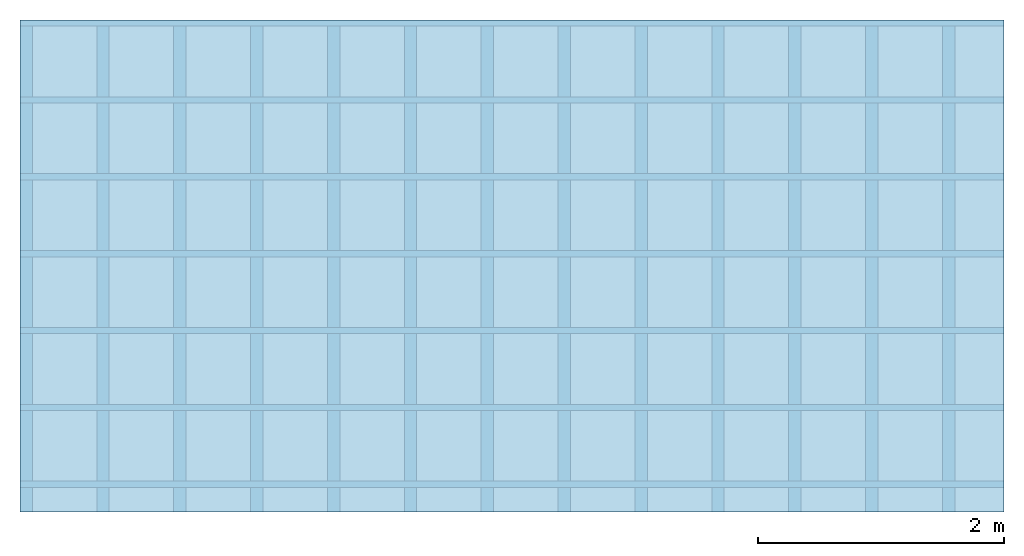
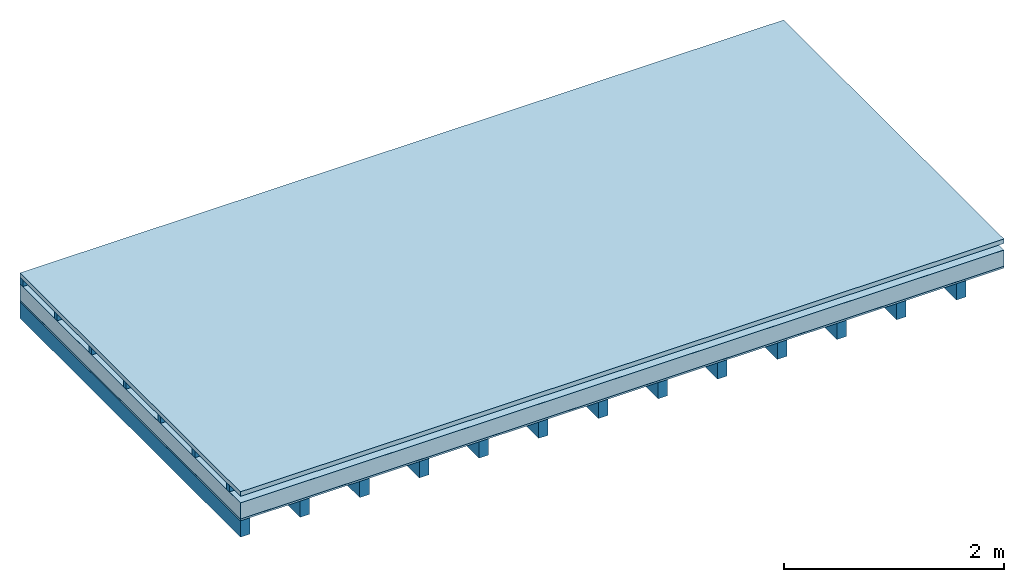
# One storey: 5 plates, 2 members, 1 element without a shape of its own.
"""IFC4 building model written with IfcOpenShell, lengths in metres."""

from ifc_helpers import new_model, si_unit, derived_unit, direction, frame, frame_2d, origin, origin_with_axes, place, context, project, spatial, rectangle, extrude, material, layer, layer_set, type_object, element, aggregate, save


model = new_model("IFC4")

# Units and contexts
plan_context = context("Plan", 3, precision=1e-05, world=origin(), true_north=direction((0.0, 1.0)))
model_context = context("Model", 3, precision=1e-05, world=origin(), true_north=direction((0.0, 1.0)))
ifc_project = project(units=[si_unit("LENGTHUNIT", "METRE"), derived_unit("SOUNDPRESSUREUNIT", [(si_unit("PRESSUREUNIT", "PASCAL", prefix="MICRO"), 0)]), si_unit("ENERGYUNIT", "JOULE", prefix="MEGA"), si_unit("MASSUNIT", "GRAM", prefix="KILO"), derived_unit("THERMALTRANSMITTANCEUNIT", [(si_unit("POWERUNIT", "WATT"), 1), (si_unit("AREAUNIT", "SQUARE_METRE"), -1), (si_unit("THERMODYNAMICTEMPERATUREUNIT", "KELVIN"), -1)]), derived_unit("AREADENSITYUNIT", [(si_unit("MASSUNIT", "GRAM", prefix="KILO"), 1), (si_unit("AREAUNIT", "SQUARE_METRE"), -1)]), derived_unit("USERDEFINED", [(si_unit("ENERGYUNIT", "JOULE", prefix="MEGA"), 1), (si_unit("AREAUNIT", "SQUARE_METRE"), -1)])], contexts=[plan_context, model_context])

# Site, building, storey
site = spatial("IfcSite", under=ifc_project)
building_placement = place(None, origin())
building = spatial("IfcBuilding", under=site, at=building_placement)
storey_placement = place(building_placement, origin())
storey = spatial("IfcBuildingStorey", under=building, at=storey_placement)

# Slab, members, plates
ifc_material_1 = material(Name="Roof tiles", Category="03.015")
ifc_layer_1 = layer(ifc_material_1, 0.05, Name="Roofing")
ifc_layer_2 = layer(None, 0.072, Name="Battens / profiles")
ifc_material_2 = material(Name="Roofing underlay", Category="09.008")
ifc_layer_3 = layer(ifc_material_2, 0.00018, Name="Under the roof")
ifc_material_3 = material(Category="10.009")
ifc_layer_4 = layer(ifc_material_3, 0.18, Name="Exterior insulation layer 1")
ifc_material_4 = material(Name="Vapor barrier polyethylene (PE)", Category="09.002")
ifc_layer_5 = layer(ifc_material_4, 0.00018, Name="above 1st layer")
ifc_material_5 = material(Name="Boards with edges", Category="07.009")
ifc_layer_6 = layer(ifc_material_5, 0.02, Name="Sub-floor")
ifc_material_6 = material(Name="of the art")
ifc_layer_7 = layer(ifc_material_6, 0.0, Name="Bond")
ifc_layer_8 = layer(None, 0.18, Name="Supporting structure")
ifc_layer_set = layer_set([ifc_layer_1, ifc_layer_2, ifc_layer_3, ifc_layer_4, ifc_layer_5, ifc_layer_6, ifc_layer_7, ifc_layer_8])
slab_type = type_object("IfcSlabType", Name="E0172", PredefinedType="NOTDEFINED", material=ifc_layer_set)
slab_placement = place(None, frame((0.0, 0.0, 0.0), z_axis=(0.0, 0.0, -1.0), x_axis=(1.0, 0.0, 0.0)))
slab = element("IfcSlab", 1, at=slab_placement, inside=storey, type_object=slab_type, material=ifc_layer_set, Name="Slab #1")
ifc_material_7 = material()
member_1_placement = place(slab_placement, origin())
member_1 = element("IfcMember", 2, at=member_1_placement, material=ifc_material_7, Name="Battens / profiles", context=plan_context, shape_type="SweptSolid", body=[
    extrude(rectangle(XDim=0.05, YDim=0.072, at=frame_2d((0.025, 0.036), x_axis=(1.0, 0.0))), frame((0.0, 0.0, 0.05), z_axis=(1.0, 0.0, 0.0), x_axis=(0.0, 1.0, 0.0)), (0.0, 0.0, 1.0), 8.0),
    extrude(rectangle(XDim=0.05, YDim=0.072, at=frame_2d((0.025, 0.036), x_axis=(1.0, 0.0))), frame((0.0, 0.625, 0.05), z_axis=(1.0, 0.0, 0.0), x_axis=(0.0, 1.0, 0.0)), (0.0, 0.0, 1.0), 8.0),
    extrude(rectangle(XDim=0.05, YDim=0.072, at=frame_2d((0.025, 0.036), x_axis=(1.0, 0.0))), frame((0.0, 1.25, 0.05), z_axis=(1.0, 0.0, 0.0), x_axis=(0.0, 1.0, 0.0)), (0.0, 0.0, 1.0), 8.0),
    extrude(rectangle(XDim=0.05, YDim=0.072, at=frame_2d((0.025, 0.036), x_axis=(1.0, 0.0))), frame((0.0, 1.875, 0.05), z_axis=(1.0, 0.0, 0.0), x_axis=(0.0, 1.0, 0.0)), (0.0, 0.0, 1.0), 8.0),
    extrude(rectangle(XDim=0.05, YDim=0.072, at=frame_2d((0.025, 0.036), x_axis=(1.0, 0.0))), frame((0.0, 2.5, 0.05), z_axis=(1.0, 0.0, 0.0), x_axis=(0.0, 1.0, 0.0)), (0.0, 0.0, 1.0), 8.0),
    extrude(rectangle(XDim=0.05, YDim=0.072, at=frame_2d((0.025, 0.036), x_axis=(1.0, 0.0))), frame((0.0, 3.125, 0.05), z_axis=(1.0, 0.0, 0.0), x_axis=(0.0, 1.0, 0.0)), (0.0, 0.0, 1.0), 8.0),
    extrude(rectangle(XDim=0.05, YDim=0.072, at=frame_2d((0.025, 0.036), x_axis=(1.0, 0.0))), frame((0.0, 3.75, 0.05), z_axis=(1.0, 0.0, 0.0), x_axis=(0.0, 1.0, 0.0)), (0.0, 0.0, 1.0), 8.0),
])
ifc_material_8 = material()
member_2_placement = place(slab_placement, origin())
member_2 = element("IfcMember", 3, at=member_2_placement, material=ifc_material_8, Name="Supporting structure", context=plan_context, shape_type="SweptSolid", body=[
    extrude(rectangle(XDim=0.1, YDim=0.18, at=frame_2d((0.05, 0.09), x_axis=(1.0, 0.0))), frame((0.0, 4.0, 0.32236), z_axis=(0.0, -1.0, 0.0), x_axis=(1.0, 0.0, 0.0)), (0.0, 0.0, 1.0), 4.0),
    extrude(rectangle(XDim=0.1, YDim=0.18, at=frame_2d((0.05, 0.09), x_axis=(1.0, 0.0))), frame((0.625, 4.0, 0.32236), z_axis=(0.0, -1.0, 0.0), x_axis=(1.0, 0.0, 0.0)), (0.0, 0.0, 1.0), 4.0),
    extrude(rectangle(XDim=0.1, YDim=0.18, at=frame_2d((0.05, 0.09), x_axis=(1.0, 0.0))), frame((1.25, 4.0, 0.32236), z_axis=(0.0, -1.0, 0.0), x_axis=(1.0, 0.0, 0.0)), (0.0, 0.0, 1.0), 4.0),
    extrude(rectangle(XDim=0.1, YDim=0.18, at=frame_2d((0.05, 0.09), x_axis=(1.0, 0.0))), frame((1.875, 4.0, 0.32236), z_axis=(0.0, -1.0, 0.0), x_axis=(1.0, 0.0, 0.0)), (0.0, 0.0, 1.0), 4.0),
    extrude(rectangle(XDim=0.1, YDim=0.18, at=frame_2d((0.05, 0.09), x_axis=(1.0, 0.0))), frame((2.5, 4.0, 0.32236), z_axis=(0.0, -1.0, 0.0), x_axis=(1.0, 0.0, 0.0)), (0.0, 0.0, 1.0), 4.0),
    extrude(rectangle(XDim=0.1, YDim=0.18, at=frame_2d((0.05, 0.09), x_axis=(1.0, 0.0))), frame((3.125, 4.0, 0.32236), z_axis=(0.0, -1.0, 0.0), x_axis=(1.0, 0.0, 0.0)), (0.0, 0.0, 1.0), 4.0),
    extrude(rectangle(XDim=0.1, YDim=0.18, at=frame_2d((0.05, 0.09), x_axis=(1.0, 0.0))), frame((3.75, 4.0, 0.32236), z_axis=(0.0, -1.0, 0.0), x_axis=(1.0, 0.0, 0.0)), (0.0, 0.0, 1.0), 4.0),
    extrude(rectangle(XDim=0.1, YDim=0.18, at=frame_2d((0.05, 0.09), x_axis=(1.0, 0.0))), frame((4.375, 4.0, 0.32236), z_axis=(0.0, -1.0, 0.0), x_axis=(1.0, 0.0, 0.0)), (0.0, 0.0, 1.0), 4.0),
    extrude(rectangle(XDim=0.1, YDim=0.18, at=frame_2d((0.05, 0.09), x_axis=(1.0, 0.0))), frame((5.0, 4.0, 0.32236), z_axis=(0.0, -1.0, 0.0), x_axis=(1.0, 0.0, 0.0)), (0.0, 0.0, 1.0), 4.0),
    extrude(rectangle(XDim=0.1, YDim=0.18, at=frame_2d((0.05, 0.09), x_axis=(1.0, 0.0))), frame((5.625, 4.0, 0.32236), z_axis=(0.0, -1.0, 0.0), x_axis=(1.0, 0.0, 0.0)), (0.0, 0.0, 1.0), 4.0),
    extrude(rectangle(XDim=0.1, YDim=0.18, at=frame_2d((0.05, 0.09), x_axis=(1.0, 0.0))), frame((6.25, 4.0, 0.32236), z_axis=(0.0, -1.0, 0.0), x_axis=(1.0, 0.0, 0.0)), (0.0, 0.0, 1.0), 4.0),
    extrude(rectangle(XDim=0.1, YDim=0.18, at=frame_2d((0.05, 0.09), x_axis=(1.0, 0.0))), frame((6.875, 4.0, 0.32236), z_axis=(0.0, -1.0, 0.0), x_axis=(1.0, 0.0, 0.0)), (0.0, 0.0, 1.0), 4.0),
    extrude(rectangle(XDim=0.1, YDim=0.18, at=frame_2d((0.05, 0.09), x_axis=(1.0, 0.0))), frame((7.5, 4.0, 0.32236), z_axis=(0.0, -1.0, 0.0), x_axis=(1.0, 0.0, 0.0)), (0.0, 0.0, 1.0), 4.0),
])
plate_1_placement = place(slab_placement, origin())
plate_1 = element("IfcPlate", 4, at=plate_1_placement, material=ifc_material_1, Name="Roofing", context=plan_context, shape_type="SweptSolid", body=[
    extrude(rectangle(XDim=8.0, YDim=4.0, at=frame_2d((4.0, 2.0), x_axis=(1.0, 0.0))), origin_with_axes(), (0.0, 0.0, 1.0), 0.05),
])
plate_2_placement = place(slab_placement, origin())
plate_2 = element("IfcPlate", 5, at=plate_2_placement, material=ifc_material_2, Name="Under the roof", context=plan_context, shape_type="SweptSolid", body=[
    extrude(rectangle(XDim=8.0, YDim=4.0, at=frame_2d((4.0, 2.0), x_axis=(1.0, 0.0))), frame((0.0, 0.0, 0.122), z_axis=(0.0, 0.0, 1.0), x_axis=(1.0, 0.0, 0.0)), (0.0, 0.0, 1.0), 0.00018),
])
plate_3_placement = place(slab_placement, origin())
plate_3 = element("IfcPlate", 6, at=plate_3_placement, material=ifc_material_3, Name="Exterior insulation layer 1", context=plan_context, shape_type="SweptSolid", body=[
    extrude(rectangle(XDim=8.0, YDim=4.0, at=frame_2d((4.0, 2.0), x_axis=(1.0, 0.0))), frame((0.0, 0.0, 0.12218), z_axis=(0.0, 0.0, 1.0), x_axis=(1.0, 0.0, 0.0)), (0.0, 0.0, 1.0), 0.18),
])
plate_4_placement = place(slab_placement, origin())
plate_4 = element("IfcPlate", 7, at=plate_4_placement, material=ifc_material_4, Name="above 1st layer", context=plan_context, shape_type="SweptSolid", body=[
    extrude(rectangle(XDim=8.0, YDim=4.0, at=frame_2d((4.0, 2.0), x_axis=(1.0, 0.0))), frame((0.0, 0.0, 0.30218), z_axis=(0.0, 0.0, 1.0), x_axis=(1.0, 0.0, 0.0)), (0.0, 0.0, 1.0), 0.00018),
])
plate_5_placement = place(slab_placement, origin())
plate_5 = element("IfcPlate", 8, at=plate_5_placement, material=ifc_material_5, Name="Sub-floor", context=plan_context, shape_type="SweptSolid", body=[
    extrude(rectangle(XDim=8.0, YDim=4.0, at=frame_2d((4.0, 2.0), x_axis=(1.0, 0.0))), frame((0.0, 0.0, 0.30236), z_axis=(0.0, 0.0, 1.0), x_axis=(1.0, 0.0, 0.0)), (0.0, 0.0, 1.0), 0.02),
])
aggregate(slab, [plate_1, member_1, plate_2, plate_3, plate_4, plate_5, member_2])

save(model, "model.ifc")
